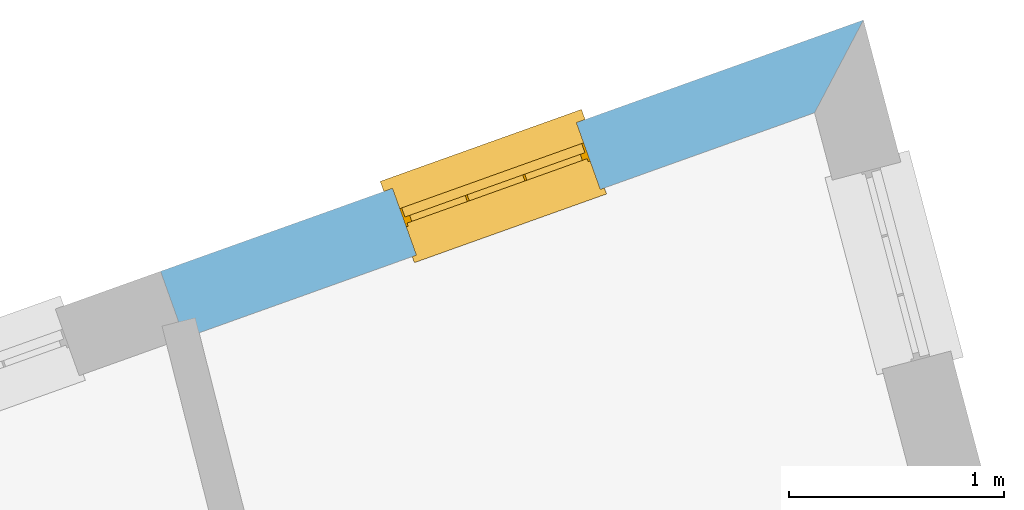
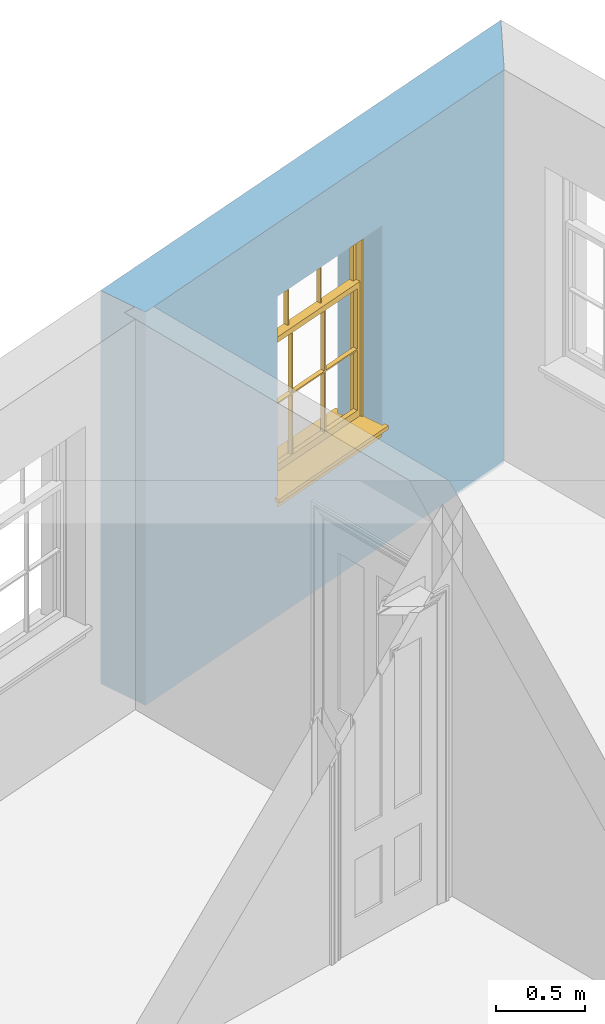
# One storey, part 15 of 15: 1 window, 1 opening, plus 1 element that does not belong to this part.
"""IFC2X3 building model written with IfcOpenShell, lengths in metres."""

from ifc_helpers import new_model, si_unit, frame, origin, place, context, subcontext, project, spatial, polyline, outline, extrude, faceted_brep, material, layer, layer_set, layer_usage, element, fill, save


model = new_model("IFC2X3")

# Units and contexts
model_context = context("Model", 3, world=origin())
body_context = subcontext(model_context, "Body", "Model", "MODEL_VIEW")
ifc_project = project(units=[si_unit("PLANEANGLEUNIT", "RADIAN"), si_unit("MASSUNIT", "GRAM", prefix="KILO"), si_unit("FORCEUNIT", "NEWTON", prefix="KILO"), si_unit("LENGTHUNIT", "METRE")], contexts=[model_context])

# Site, building, storey
site_placement = place(None, origin())
site = spatial("IfcSite", under=ifc_project, at=site_placement, CompositionType="ELEMENT")
building_placement = place(None, origin())
building = spatial("IfcBuilding", under=site, at=building_placement, Name="Building plot-13", CompositionType="ELEMENT")
storey_placement = place(None, frame((0.0, 0.0, 4.0)))
storey = spatial("IfcBuildingStorey", under=building, at=storey_placement, Name="Floor 0", CompositionType="ELEMENT", Elevation=4.0)

# Wall, opening, window
ifc_material = material(Name="Masonry")
ifc_layer = layer(ifc_material, 0.33, ventilated=False)
ifc_layer_set = layer_set([ifc_layer], Name="My Wall")
ifc_layer_usage = layer_usage(ifc_layer_set, "AXIS2", "NEGATIVE", 0.08)
wall_placement = place(storey_placement, origin())
wall = element("IfcWallStandardCase", 1, at=wall_placement, inside=storey, material=ifc_layer_usage, Name="exterior", context=body_context, shape_type="SweptSolid", body=[
    extrude(outline(polyline([(78.699089450727, 52.1144212259562), (78.9265356735152, 52.5462115674965), (75.6540271002417, 51.3760559996695), (75.765136209946, 51.0653233722537), (78.699089450727, 52.1144212259562)])), origin(), (0.0, 0.0, 1.0), 2.7),
])
opening_placement = place(storey_placement, frame((0.0, 0.0, 0.75)))
opening = element("IfcOpeningElement", 2, at=opening_placement, cuts=wall, Name="Opening", ObjectType="Opening", context=body_context, shape_type="SweptSolid", body=[
    extrude(outline(polyline([(77.5904751108561, 52.0684744825221), (76.7336063504065, 51.7620826951557), (76.8447154601108, 51.4513500677399), (77.7015842205604, 51.7577418551063), (77.5904751108561, 52.0684744825221)])), origin(), (0.0, 0.0, 1.0), 1.445),
])
window_placement = place(storey_placement, frame((77.6746486788139, 51.833070976904, 0.75), z_axis=(0.0, 0.0, 1.0), x_axis=(-0.856868760449601, -0.306391787366394, 0.0)))
window = element("IfcWindow", 3, at=window_placement, inside=storey, Name="living street window", OverallHeight=1.445, OverallWidth=0.91, context=body_context, shape_type="Brep", held_by="IfcProductRepresentation", body=[
    faceted_brep([(0.876875, -0.105, 0.999097), (0.876875, -0.105, 1.411875), (0.9, -0.105, 1.435), (0.033125, -0.105, 1.411875), (0.033125, -0.105, 0.999097), (0.01, -0.105, 1.435), (0.033125, -0.135, 1.411875), (0.01, -0.135, 1.435), (0.033125, -0.135, 0.999097), (0.876875, -0.135, 1.411875), (0.876875, -0.135, 0.999097), (0.9, -0.135, 1.435), (0.033125, -0.105, 0.960972), (0.01, -0.105, 0.960972), (0.033125, -0.105, 0.548195), (0.876875, -0.105, 0.960972), (0.876875, -0.105, 0.548195), (0.9, -0.105, 0.960972), (0.876875, -0.105, 0.538195), (0.876875, -0.105, 0.125417), (0.9, -0.105, 0.077167), (0.033125, -0.105, 0.125417), (0.033125, -0.105, 0.538195), (0.01, -0.105, 0.077167), (0.9, -0.135, 0.960972), (0.01, -0.135, 0.960972), (-0.0425, -0.25, 0.01), (-0.0425, -0.3, 0.001667), (0.0, -0.25, 0.01), (0.9525, -0.25, 0.01), (0.91, -0.25, 0.01), (0.9525, -0.3, 0.001667), (-0.02, 0.08, 0.077167), (0.0, 0.08, 0.077167), (-0.02, 0.11, 0.077167), (0.0, -0.06, 0.077167), (0.01, -0.06, 0.077167), (0.91, -0.06, 0.077167), (0.91, 0.08, 0.077167), (0.9, -0.06, 0.077167), (0.93, 0.08, 0.077167), (0.93, 0.11, 0.077167), (0.01, -0.105, 0.999097), (0.01, -0.075, 0.999097), (0.9, -0.105, 0.999097), (0.9, -0.075, 0.999097), (0.876875, -0.075, 0.125417), (0.876875, -0.075, 0.538195), (0.9, -0.075, 0.077167), (0.876875, -0.075, 0.548195), (0.876875, -0.075, 0.960972), (0.033125, -0.075, 0.125417), (0.01, -0.075, 0.077167), (0.033125, -0.075, 0.538195), (0.033125, -0.075, 0.960972), (0.033125, -0.075, 0.548195), (-0.02, 0.08, 0.052167), (-0.02, 0.11, 0.052167), (0.93, 0.11, 0.052167), (0.93, 0.08, 0.052167), (0.91, 0.08, 0.052167), (0.0, 0.08, 0.052167), (0.91, -0.15, 0.026667), (0.0, -0.15, 0.026667), (-0.0425, -0.3, -0.123333), (0.9525, -0.3, -0.123333), (-0.0425, -0.25, -0.123333), (0.9525, -0.25, -0.123333), (0.01, -0.06, 1.435), (0.9, -0.06, 1.435), (0.0, -0.06, 1.445), (0.91, -0.06, 1.445), (0.01, -0.15, 0.077167), (0.9, -0.15, 0.077167), (0.592292, -0.105, 0.125417), (0.592292, -0.075, 0.125417), (0.317708, -0.075, 0.125417), (0.317708, -0.105, 0.125417), (0.592292, -0.105, 0.548195), (0.317708, -0.105, 0.548195), (0.317708, -0.105, 0.538195), (0.592292, -0.105, 0.538195), (0.592292, -0.075, 0.548195), (0.317708, -0.075, 0.548195), (0.602292, -0.075, 0.548195), (0.602292, -0.105, 0.548195), (0.317708, -0.075, 0.538195), (0.307708, -0.075, 0.125417), (0.307708, -0.075, 0.538195), (0.602292, -0.075, 0.538195), (0.602292, -0.075, 0.125417), (0.592292, -0.075, 0.538195), (0.307708, -0.075, 0.548195), (0.317708, -0.075, 0.960972), (0.307708, -0.075, 0.960972), (0.602292, -0.075, 0.960972), (0.592292, -0.075, 0.960972), (0.307708, -0.105, 0.538195), (0.307708, -0.105, 0.125417), (0.307708, -0.105, 0.548195), (0.307708, -0.105, 0.960972), (0.592292, -0.105, 0.960972), (0.317708, -0.105, 0.960972), (0.602292, -0.105, 0.960972), (0.602292, -0.105, 0.538195), (0.602292, -0.105, 0.125417), (0.317708, -0.135, 1.411875), (0.307708, -0.135, 1.411875), (0.307708, -0.135, 0.999097), (0.317708, -0.135, 0.999097), (0.602292, -0.135, 1.411875), (0.592292, -0.135, 1.411875), (0.592292, -0.135, 0.999097), (0.602292, -0.135, 0.999097), (0.317708, -0.105, 0.999097), (0.307708, -0.105, 0.999097), (0.307708, -0.105, 1.411875), (0.317708, -0.105, 1.411875), (0.602292, -0.105, 0.999097), (0.592292, -0.105, 0.999097), (0.592292, -0.105, 1.411875), (0.602292, -0.105, 1.411875), (0.91, -0.15, 1.445), (0.9, -0.15, 1.435), (0.01, -0.15, 1.435), (0.0, -0.15, 1.445), (0.91, -0.25, 0.0), (0.0, -0.25, 0.0), (0.91, 0.08, 0.0), (0.0, 0.08, 0.0)], [[[0, 1, 2]], [[3, 4, 5]], [[6, 7, 8]], [[9, 10, 11]], [[12, 13, 14]], [[15, 16, 17]], [[18, 19, 20]], [[21, 22, 23]], [[24, 15, 17]], [[13, 12, 25]], [[26, 27, 28]], [[29, 30, 31]], [[32, 33, 34]], [[35, 36, 33]], [[37, 38, 39]], [[40, 41, 38]], [[42, 4, 43]], [[44, 45, 0]], [[46, 47, 48]], [[49, 50, 45]], [[51, 52, 53]], [[54, 55, 43]], [[38, 33, 36, 39]], [[41, 34, 33, 38]], [[56, 32, 34, 57]], [[57, 34, 41, 58]], [[58, 41, 40, 59]], [[57, 58, 60, 61]], [[52, 48, 39, 36]], [[62, 63, 28, 30]], [[27, 31, 30, 28]], [[27, 64, 65, 31]], [[66, 67, 65, 64]], [[2, 5, 68, 69]], [[68, 70, 71, 69]], [[20, 23, 72, 73]], [[73, 72, 63, 62]], [[74, 75, 76, 77]], [[78, 79, 80, 81]], [[78, 82, 83, 79]], [[16, 49, 84, 85]], [[86, 76, 87, 88]], [[89, 90, 75, 91]], [[92, 88, 53, 55]], [[82, 91, 86, 83]], [[93, 83, 92, 94]], [[95, 84, 82, 96]], [[89, 84, 49, 47]], [[97, 88, 87, 98]], [[22, 53, 88, 97]], [[81, 91, 75, 74]], [[80, 86, 91, 81]], [[77, 76, 86, 80]], [[99, 92, 55, 14]], [[100, 94, 92, 99]], [[101, 96, 82, 78]], [[79, 83, 93, 102]], [[85, 84, 95, 103]], [[104, 89, 47, 18]], [[105, 90, 89, 104]], [[104, 18, 16, 85]], [[80, 97, 98, 77]], [[104, 81, 74, 105]], [[103, 101, 78, 85]], [[99, 14, 22, 97]], [[102, 100, 99, 79]], [[106, 107, 108, 109]], [[110, 111, 112, 113]], [[114, 115, 116, 117]], [[118, 119, 120, 121]], [[107, 116, 115, 108]], [[111, 120, 119, 112]], [[109, 114, 117, 106]], [[113, 118, 121, 110]], [[85, 78, 81, 104]], [[84, 89, 91, 82]], [[83, 86, 88, 92]], [[79, 99, 97, 80]], [[109, 112, 119, 114]], [[102, 93, 96, 101]], [[106, 117, 120, 111]], [[98, 87, 51, 21]], [[6, 3, 116, 107]], [[110, 121, 1, 9]], [[19, 46, 90, 105]], [[26, 66, 64, 27]], [[29, 31, 65, 67]], [[25, 24, 112, 109]], [[11, 7, 106, 111]], [[75, 48, 52, 76]], [[43, 45, 96, 93]], [[45, 43, 114, 119]], [[5, 2, 120, 117]], [[24, 25, 102, 101]], [[42, 5, 4]], [[2, 44, 0]], [[49, 45, 48, 47]], [[52, 43, 55, 53]], [[14, 13, 23, 22]], [[20, 17, 16, 18]], [[24, 11, 10]], [[25, 8, 7]], [[8, 4, 3, 6]], [[9, 1, 0, 10]], [[15, 50, 49, 16]], [[18, 47, 46, 19]], [[21, 51, 53, 22]], [[14, 55, 54, 12]], [[44, 2, 69, 45]], [[68, 5, 42, 43]], [[36, 35, 70, 68]], [[39, 69, 71, 37]], [[62, 122, 123, 73]], [[63, 72, 124, 125]], [[8, 108, 115, 4]], [[113, 10, 0, 118]], [[94, 100, 12, 54]], [[17, 20, 73, 24]], [[72, 23, 13, 25]], [[52, 36, 68, 43]], [[69, 39, 48, 45]], [[11, 24, 73, 123]], [[7, 124, 72, 25]], [[23, 77, 98]], [[98, 21, 23]], [[105, 74, 20]], [[20, 19, 105]], [[20, 74, 77, 23]], [[113, 112, 24]], [[24, 10, 113]], [[25, 109, 108]], [[108, 8, 25]], [[110, 9, 11]], [[11, 111, 110]], [[7, 6, 107]], [[107, 106, 7]], [[5, 117, 116]], [[116, 3, 5]], [[121, 120, 2]], [[2, 1, 121]], [[11, 123, 124, 7]], [[122, 125, 124, 123]], [[43, 93, 94]], [[94, 54, 43]], [[96, 45, 95]], [[50, 95, 45]], [[15, 103, 95, 50]], [[48, 75, 90]], [[90, 46, 48]], [[87, 76, 52]], [[52, 51, 87]], [[103, 15, 24]], [[24, 101, 103]], [[100, 102, 25]], [[25, 12, 100]], [[115, 114, 43]], [[43, 4, 115]], [[118, 0, 45]], [[45, 119, 118]], [[71, 70, 125, 122]], [[70, 35, 63, 125]], [[122, 62, 37, 71]], [[126, 67, 66, 127]], [[60, 58, 59]], [[38, 60, 59, 40]], [[61, 56, 57]], [[32, 56, 61, 33]], [[61, 60, 128, 129]], [[62, 60, 38, 37]], [[126, 128, 60, 62]], [[33, 61, 63, 35]], [[61, 129, 127, 63]], [[128, 126, 127, 129]], [[28, 127, 66, 26]], [[63, 127, 28]], [[29, 67, 126, 30]], [[30, 126, 62]]]),
])
fill(opening, window)

save(model, "model.ifc")
